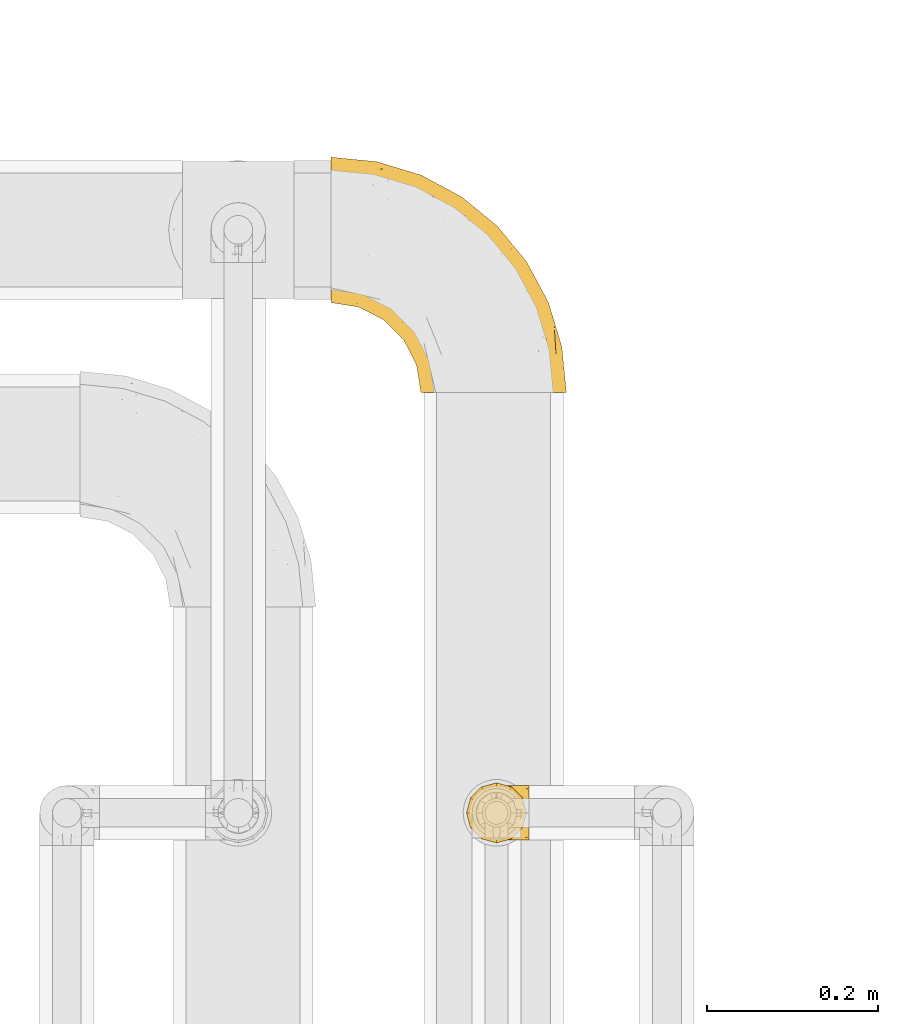
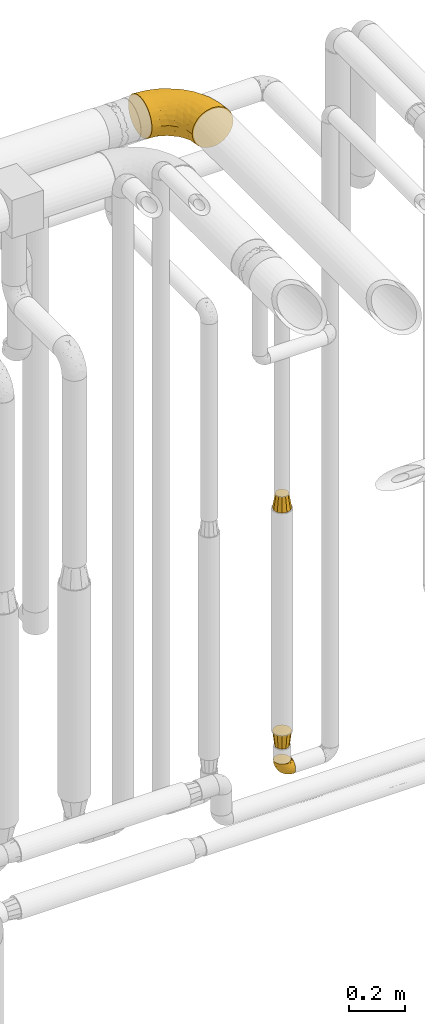
# One storey, part 503 of 827: 4 coverings.
"""IFC2X3 building model written with IfcOpenShell, lengths in millimetres."""

from ifc_helpers import new_model, entity, si_unit, converted_unit, derived_unit, direction, frame, origin, place, context, subcontext, project, spatial, faceted_brep, element, save


model = new_model("IFC2X3")

# Units and contexts
model_context = context("Model", 3, precision=0.01, world=origin(), true_north=direction((6.12303176911189e-17, 1.0)))
body_context = subcontext(model_context, "Body", "Model", "MODEL_VIEW")
ifc_project = project(units=[si_unit("LENGTHUNIT", "METRE", prefix="MILLI"), si_unit("AREAUNIT", "SQUARE_METRE"), si_unit("VOLUMEUNIT", "CUBIC_METRE"), converted_unit("PLANEANGLEUNIT", "DEGREE", entity("IfcRatioMeasure", 0.0174532925199433), si_unit("PLANEANGLEUNIT", "RADIAN"), dimensions=[0, 0, 0, 0, 0, 0, 0]), si_unit("MASSUNIT", "GRAM", prefix="KILO"), derived_unit("MASSDENSITYUNIT", [(si_unit("MASSUNIT", "GRAM", prefix="KILO"), 1), (si_unit("LENGTHUNIT", "METRE"), -3)]), derived_unit("MOMENTOFINERTIAUNIT", [(si_unit("LENGTHUNIT", "METRE"), 4)]), si_unit("TIMEUNIT", "SECOND"), si_unit("FREQUENCYUNIT", "HERTZ"), si_unit("THERMODYNAMICTEMPERATUREUNIT", "DEGREE_CELSIUS"), derived_unit("THERMALTRANSMITTANCEUNIT", [(si_unit("MASSUNIT", "GRAM", prefix="KILO"), 1), (si_unit("THERMODYNAMICTEMPERATUREUNIT", "KELVIN"), -1), (si_unit("TIMEUNIT", "SECOND"), -3)]), derived_unit("VOLUMETRICFLOWRATEUNIT", [(si_unit("LENGTHUNIT", "METRE"), 3), (si_unit("TIMEUNIT", "SECOND"), -1)]), derived_unit("MASSFLOWRATEUNIT", [(si_unit("MASSUNIT", "GRAM", prefix="KILO"), 1), (si_unit("TIMEUNIT", "SECOND"), -1)]), derived_unit("ROTATIONALFREQUENCYUNIT", [(si_unit("TIMEUNIT", "SECOND"), -1)]), si_unit("ELECTRICCURRENTUNIT", "AMPERE"), si_unit("ELECTRICVOLTAGEUNIT", "VOLT"), si_unit("POWERUNIT", "WATT"), si_unit("FORCEUNIT", "NEWTON", prefix="KILO"), si_unit("ILLUMINANCEUNIT", "LUX"), si_unit("LUMINOUSFLUXUNIT", "LUMEN"), si_unit("LUMINOUSINTENSITYUNIT", "CANDELA"), derived_unit("USERDEFINED", [(si_unit("MASSUNIT", "GRAM", prefix="KILO"), -1), (si_unit("LENGTHUNIT", "METRE"), -2), (si_unit("TIMEUNIT", "SECOND"), 3), (si_unit("LUMINOUSFLUXUNIT", "LUMEN"), 1)]), derived_unit("LINEARVELOCITYUNIT", [(si_unit("LENGTHUNIT", "METRE"), 1), (si_unit("TIMEUNIT", "SECOND"), -1)]), si_unit("PRESSUREUNIT", "PASCAL"), derived_unit("USERDEFINED", [(si_unit("LENGTHUNIT", "METRE"), -2), (si_unit("MASSUNIT", "GRAM", prefix="KILO"), 1), (si_unit("TIMEUNIT", "SECOND"), -2)]), derived_unit("LINEARFORCEUNIT", [(si_unit("MASSUNIT", "GRAM", prefix="KILO"), 1), (si_unit("LENGTHUNIT", "METRE"), 1), (si_unit("TIMEUNIT", "SECOND"), -2), (si_unit("LENGTHUNIT", "METRE"), -1)]), derived_unit("PLANARFORCEUNIT", [(si_unit("MASSUNIT", "GRAM", prefix="KILO"), 1), (si_unit("LENGTHUNIT", "METRE"), 1), (si_unit("TIMEUNIT", "SECOND"), -2), (si_unit("LENGTHUNIT", "METRE"), -2)])], contexts=[model_context])

# Site, building, storey
site_placement = place(None, origin())
site = spatial("IfcSite", under=ifc_project, at=site_placement, CompositionType="ELEMENT")
building_placement = place(site_placement, origin())
building = spatial("IfcBuilding", under=site, at=building_placement, CompositionType="ELEMENT")
storey_placement = place(building_placement, frame((0.0, 0.0, 28200.0)))
storey = spatial("IfcBuildingStorey", under=building, at=storey_placement, Name="08", CompositionType="ELEMENT", Elevation=28200.0)

# Coverings
covering_1_placement = place(storey_placement, frame((60420.94, 17466.55, 366.55)))
element("IfcCovering", 1, at=covering_1_placement, inside=storey, Name=":ADSK_", ObjectType=":ADSK_", PredefinedType="INSULATION", context=body_context, shape_type="Brep", body=[
    faceted_brep([(2.39, 40.53, 71.45), (1.6, 33.45, 71.45), (2.39, 26.35, 71.45), (4.75, 19.62, 71.45), (8.55, 13.58, 71.45), (13.59, 8.54, 71.45), (19.63, 4.75, 71.45), (26.36, 2.39, 71.45), (33.45, 1.6, 71.45), (37.35, 2.04, 71.45), (40.54, 2.39, 71.45), (43.9, 3.57, 71.45), (47.27, 4.75, 71.45), (53.31, 8.55, 71.45), (58.35, 13.59, 71.45), (62.14, 19.63, 71.45), (64.5, 26.36, 71.45), (65.3, 33.45, 71.45), (64.5, 40.54, 71.45), (62.14, 47.27, 71.45), (58.34, 53.31, 71.45), (53.3, 58.35, 71.45), (47.26, 62.14, 71.45), (43.89, 63.32, 71.45), (40.53, 64.5, 71.45), (37.35, 64.86, 71.45), (35.4, 65.08, 71.45), (33.45, 65.3, 71.45), (26.35, 64.5, 71.45), (19.62, 62.14, 71.45), (13.58, 58.34, 71.45), (8.54, 53.3, 71.45), (4.75, 47.26, 71.45), (71.45, 5.86, 49.37), (71.45, 4.27, 45.53), (71.45, 2.68, 41.69), (71.45, 2.11, 37.37), (71.45, 1.85, 35.41), (71.45, 1.6, 33.45), (71.45, 2.68, 25.2), (71.45, 5.86, 17.52), (71.45, 10.92, 10.92), (71.45, 17.52, 5.86), (71.45, 25.2, 2.68), (71.45, 33.45, 1.6), (71.45, 41.69, 2.68), (71.45, 49.37, 5.86), (71.45, 55.97, 10.92), (71.45, 61.03, 17.52), (71.45, 64.21, 25.2), (71.45, 65.3, 33.45), (71.45, 64.78, 37.37), (71.45, 64.21, 41.69), (71.45, 62.62, 45.53), (71.45, 61.03, 49.37), (71.45, 58.5, 52.67), (71.45, 55.97, 55.97), (71.45, 49.37, 61.03), (71.45, 41.69, 64.21), (71.45, 33.45, 65.3), (71.45, 25.2, 64.21), (71.45, 17.52, 61.03), (71.45, 10.92, 55.97), (71.45, 8.39, 52.67), (37.48, 64.03, 39.1), (38.54, 65.3, 52.45), (42.01, 65.3, 48.97), (45.49, 65.3, 45.49), (48.97, 65.3, 42.01), (52.45, 65.3, 38.54), (58.08, 33.45, 4.25), (40.84, 56.13, 19.42), (47.91, 61.0, 22.87), (55.67, 57.25, 14.43), (55.18, 44.44, 5.53), (45.13, 50.33, 12.01), (59.19, 51.72, 8.54), (11.67, 54.4, 55.06), (38.17, 41.87, 11.33), (28.82, 48.25, 20.79), (29.48, 64.6, 56.32), (32.11, 60.78, 33.95), (24.68, 61.71, 47.18), (55.82, 64.46, 28.97), (28.37, 55.78, 28.68), (9.18, 40.71, 41.69), (4.95, 42.87, 55.32), (11.17, 47.87, 43.59), (60.89, 62.12, 20.67), (55.35, 65.3, 37.76), (58.25, 65.3, 36.98), (61.15, 65.3, 36.2), (64.05, 65.3, 35.43), (65.9, 65.3, 34.93), (67.75, 65.3, 34.44), (16.27, 59.32, 58.97), (6.97, 49.35, 59.39), (4.25, 33.45, 58.08), (21.84, 62.53, 59.72), (33.94, 65.3, 69.6), (34.44, 65.3, 67.75), (35.43, 65.3, 64.05), (36.2, 65.3, 61.15), (36.98, 65.3, 58.25), (37.76, 65.3, 55.35), (18.84, 57.03, 43.85), (14.39, 52.84, 44.13), (51.68, 38.52, 4.87), (6.91, 33.45, 44.71), (26.05, 41.09, 19.59), (33.38, 33.45, 14.48), (22.05, 33.45, 22.05), (17.7, 44.35, 29.9), (19.21, 51.29, 33.81), (44.71, 33.45, 6.91), (17.7, 38.44, 27.44), (14.48, 33.45, 33.38), (66.98, 57.42, 55.01), (65.01, 61.06, 50.28), (61.98, 61.24, 51.09), (64.85, 64.58, 40.86), (62.15, 64.0, 43.96), (48.67, 64.21, 52.27), (63.81, 44.85, 68.29), (50.71, 61.42, 62.01), (48.45, 61.84, 66.26), (52.85, 59.03, 67.36), (67.6, 41.64, 65.34), (65.48, 38.8, 68.62), (67.1, 33.45, 67.1), (66.68, 54.12, 58.52), (43.2, 64.27, 61.41), (44.92, 63.33, 66.44), (58.1, 54.97, 65.71), (61.92, 54.91, 60.56), (63.17, 49.44, 65.05), (66.68, 49.79, 61.9), (56.7, 59.23, 58.97), (50.86, 62.42, 57.67), (54.42, 59.27, 62.23), (40.7, 64.6, 65.15), (57.76, 63.73, 46.86), (61.34, 50.25, 67.24), (59.9, 54.66, 63.1), (58.0, 62.35, 50.81), (62.43, 59.05, 54.65), (45.83, 64.34, 55.33), (58.99, 59.52, 56.17), (45.9, 63.71, 59.8), (67.3, 61.92, 48.09), (53.12, 64.52, 46.45), (49.43, 64.9, 46.88), (53.9, 63.33, 50.93), (52.92, 62.23, 55.61), (63.81, 22.04, 68.29), (61.35, 16.65, 67.24), (63.17, 17.46, 65.05), (56.72, 7.66, 58.97), (59.87, 12.13, 62.98), (54.39, 7.35, 61.5), (67.59, 25.25, 65.34), (40.71, 2.29, 65.15), (35.43, 1.6, 64.05), (36.2, 1.6, 61.15), (36.98, 1.6, 58.25), (65.48, 28.1, 68.62), (58.19, 4.51, 50.62), (55.78, 2.45, 45.09), (62.46, 5.62, 50.82), (69.6, 1.6, 33.94), (61.15, 1.6, 36.2), (64.05, 1.6, 35.43), (67.75, 1.6, 34.44), (67.39, 6.96, 51.55), (66.16, 4.16, 46.52), (58.11, 6.38, 54.95), (62.44, 7.84, 54.65), (61.95, 10.87, 59.16), (66.68, 17.1, 61.9), (64.85, 2.31, 40.86), (52.45, 1.6, 38.54), (48.97, 1.6, 42.01), (43.18, 2.62, 61.39), (52.88, 7.88, 67.37), (48.46, 5.05, 66.23), (34.44, 1.6, 67.75), (34.93, 1.6, 65.9), (58.11, 11.92, 65.7), (58.25, 1.6, 36.98), (60.72, 2.23, 41.66), (49.13, 2.95, 53.21), (45.49, 1.6, 45.49), (53.71, 3.29, 50.1), (44.93, 3.56, 66.44), (67.04, 9.57, 55.11), (66.6, 12.74, 58.52), (44.91, 2.39, 55.59), (50.72, 5.47, 62.01), (37.76, 1.6, 55.35), (38.54, 1.6, 52.45), (46.39, 3.46, 60.71), (57.7, 2.2, 42.77), (55.35, 1.6, 37.76), (62.73, 4.02, 47.15), (42.01, 1.6, 48.97), (55.67, 9.64, 14.42), (21.85, 4.35, 59.72), (29.49, 2.29, 56.32), (55.82, 2.43, 28.97), (38.17, 25.02, 11.33), (55.18, 22.45, 5.53), (45.12, 16.56, 12.01), (47.92, 5.89, 22.86), (37.47, 2.86, 39.12), (32.11, 6.1, 33.96), (40.85, 10.76, 19.42), (51.68, 28.37, 4.87), (60.89, 4.77, 20.67), (59.19, 15.17, 8.55), (24.69, 5.18, 47.18), (16.28, 7.56, 58.97), (18.85, 9.85, 43.86), (11.19, 19.01, 43.58), (4.95, 24.01, 55.32), (9.19, 26.18, 41.67), (11.68, 12.48, 55.05), (26.05, 25.8, 19.59), (19.23, 15.6, 33.79), (14.4, 14.04, 44.12), (6.97, 17.53, 59.39), (28.8, 18.64, 20.81), (17.7, 22.54, 29.91), (28.37, 11.1, 28.68), (17.7, 28.45, 27.45)], [[[0, 1, 2, 3, 4, 5, 6, 7, 8, 9, 10, 11, 12, 13, 14, 15, 16, 17, 18, 19, 20, 21, 22, 23, 24, 25, 26, 27, 28, 29, 30, 31, 32]], [[33, 34, 35, 36, 37, 38, 39, 40, 41, 42, 43, 44, 45, 46, 47, 48, 49, 50, 51, 52, 53, 54, 55, 56, 57, 58, 59, 60, 61, 62, 63]], [[64, 65, 66, 67, 68, 69]], [[45, 44, 70]], [[71, 72, 73]], [[74, 75, 76]], [[77, 31, 30]], [[75, 78, 79]], [[27, 80, 28]], [[74, 46, 45]], [[64, 81, 82]], [[46, 76, 47]], [[83, 50, 49]], [[48, 47, 73]], [[71, 79, 84]], [[85, 86, 87]], [[49, 48, 88]], [[83, 69, 89, 90, 91, 92, 93, 94, 50]], [[95, 77, 30]], [[75, 74, 78]], [[87, 86, 96]], [[96, 86, 32]], [[96, 32, 31]], [[0, 86, 97]], [[83, 64, 69]], [[98, 80, 82]], [[73, 72, 88]], [[64, 80, 65]], [[1, 0, 97]], [[80, 27, 99, 100, 101, 102, 103, 104, 65]], [[77, 105, 106]], [[64, 82, 80]], [[70, 107, 45]], [[77, 95, 105]], [[82, 95, 98]], [[95, 30, 29]], [[74, 107, 78]], [[86, 0, 32]], [[72, 71, 81]], [[85, 108, 86]], [[76, 73, 47]], [[71, 84, 81]], [[109, 110, 111]], [[87, 112, 85]], [[79, 109, 112]], [[79, 112, 113]], [[88, 83, 49]], [[64, 83, 72]], [[31, 77, 96]], [[87, 96, 77]], [[98, 95, 29]], [[105, 95, 82]], [[81, 105, 82]], [[105, 84, 113]], [[29, 28, 98]], [[114, 107, 70]], [[80, 98, 28]], [[73, 75, 71]], [[79, 71, 75]], [[74, 76, 46]], [[73, 76, 75]], [[78, 107, 114]], [[45, 107, 74]], [[87, 113, 112]], [[115, 85, 112]], [[109, 79, 78]], [[113, 87, 106]], [[116, 115, 111]], [[116, 108, 85]], [[79, 113, 84]], [[109, 78, 110]], [[115, 109, 111]], [[85, 115, 116]], [[109, 115, 112]], [[72, 81, 64]], [[105, 81, 84]], [[73, 88, 48]], [[83, 88, 72]], [[86, 108, 97]], [[78, 114, 110]], [[113, 106, 105]], [[87, 77, 106]], [[117, 118, 119]], [[52, 120, 54, 53]], [[91, 120, 52]], [[91, 90, 120]], [[90, 121, 120]], [[122, 67, 66]], [[18, 123, 19]], [[124, 125, 126]], [[127, 59, 58]], [[128, 129, 127]], [[130, 57, 117]], [[131, 132, 125]], [[19, 133, 20]], [[128, 18, 17]], [[134, 135, 136]], [[137, 138, 139]], [[131, 103, 140]], [[22, 140, 23]], [[131, 65, 104, 103]], [[99, 27, 26, 25, 24, 101, 100]], [[141, 118, 121]], [[19, 123, 142]], [[52, 51, 50, 94, 93, 92, 91]], [[129, 128, 17]], [[117, 56, 118]], [[135, 134, 143]], [[139, 126, 133]], [[119, 144, 145]], [[127, 135, 123]], [[136, 58, 57]], [[101, 24, 23]], [[124, 138, 146]], [[140, 101, 23]], [[145, 147, 134]], [[140, 132, 131]], [[140, 103, 102, 101]], [[140, 22, 132]], [[146, 148, 124]], [[121, 69, 141]], [[55, 149, 118]], [[150, 151, 152]], [[147, 137, 134]], [[144, 150, 152]], [[152, 151, 122]], [[138, 122, 146]], [[59, 127, 129]], [[123, 18, 128]], [[58, 136, 127]], [[135, 127, 136]], [[121, 90, 89, 69]], [[120, 121, 149]], [[122, 66, 146]], [[153, 122, 138]], [[141, 69, 68]], [[127, 123, 128]], [[123, 135, 142]], [[143, 142, 135]], [[19, 142, 133]], [[66, 65, 146]], [[148, 65, 131]], [[22, 21, 132]], [[125, 132, 21]], [[126, 125, 21]], [[148, 125, 124]], [[21, 20, 126]], [[133, 126, 20]], [[139, 138, 124]], [[153, 138, 137]], [[126, 139, 124]], [[139, 133, 143]], [[147, 153, 137]], [[152, 122, 153]], [[134, 136, 130]], [[137, 139, 143]], [[144, 147, 145]], [[153, 147, 152]], [[65, 148, 146]], [[125, 148, 131]], [[141, 144, 119]], [[55, 54, 149]], [[137, 143, 134]], [[142, 143, 133]], [[130, 117, 145]], [[57, 56, 117]], [[134, 130, 145]], [[57, 130, 136]], [[150, 144, 141]], [[147, 144, 152]], [[141, 68, 150]], [[151, 68, 67]], [[117, 119, 145]], [[141, 119, 118]], [[68, 151, 150]], [[122, 151, 67]], [[118, 56, 55]], [[120, 149, 54]], [[118, 149, 121]], [[154, 155, 156]], [[157, 158, 159]], [[129, 160, 59]], [[161, 162, 163, 164]], [[165, 160, 129]], [[166, 167, 168]], [[169, 38, 37, 36, 35, 170, 171, 172]], [[63, 173, 174]], [[175, 176, 177]], [[60, 178, 61]], [[179, 35, 34, 33]], [[160, 60, 59]], [[180, 167, 181]], [[129, 17, 165]], [[182, 161, 164]], [[183, 13, 184]], [[9, 8, 185, 186, 162, 10]], [[187, 155, 15]], [[188, 179, 189]], [[187, 15, 14]], [[190, 191, 192]], [[182, 193, 161]], [[194, 176, 168]], [[176, 195, 177]], [[196, 190, 197]], [[11, 10, 162]], [[11, 161, 12]], [[187, 14, 183]], [[12, 161, 193]], [[156, 158, 177]], [[165, 17, 16]], [[194, 195, 176]], [[187, 159, 158]], [[179, 174, 189]], [[182, 164, 198, 199]], [[200, 199, 196]], [[193, 184, 13]], [[194, 168, 173]], [[201, 202, 189]], [[16, 154, 165]], [[160, 156, 178]], [[160, 165, 154]], [[178, 60, 160]], [[170, 35, 179]], [[188, 170, 179]], [[189, 174, 203]], [[174, 179, 33]], [[201, 189, 203]], [[181, 192, 191]], [[167, 180, 201]], [[192, 175, 190]], [[159, 190, 157]], [[15, 154, 16]], [[204, 196, 199]], [[204, 191, 190]], [[160, 154, 156]], [[15, 155, 154]], [[158, 155, 187]], [[203, 173, 168]], [[192, 181, 167]], [[190, 196, 204]], [[200, 196, 197]], [[184, 193, 182]], [[13, 12, 193]], [[200, 184, 182]], [[184, 200, 183]], [[187, 183, 197]], [[14, 13, 183]], [[162, 161, 11]], [[63, 62, 173]], [[174, 33, 63]], [[173, 62, 194]], [[174, 173, 203]], [[62, 61, 194]], [[195, 61, 178]], [[61, 195, 194]], [[177, 195, 178]], [[156, 177, 178]], [[175, 192, 166]], [[166, 168, 176]], [[167, 203, 168]], [[175, 166, 176]], [[167, 166, 192]], [[177, 157, 175]], [[190, 175, 157]], [[187, 197, 159]], [[190, 159, 197]], [[177, 158, 157]], [[155, 158, 156]], [[167, 201, 203]], [[200, 197, 183]], [[202, 201, 180]], [[202, 188, 189]], [[199, 200, 182]], [[41, 40, 205]], [[206, 207, 7]], [[208, 38, 169, 172, 171, 170, 188, 202, 180]], [[209, 210, 211]], [[212, 213, 214]], [[212, 215, 205]], [[43, 210, 216]], [[217, 40, 39]], [[216, 114, 70]], [[208, 213, 212]], [[205, 40, 217]], [[218, 42, 41]], [[216, 209, 114]], [[42, 218, 210]], [[214, 213, 219]], [[219, 220, 221]], [[199, 207, 213]], [[213, 207, 219]], [[8, 7, 207]], [[222, 223, 224]], [[4, 225, 5]], [[2, 97, 223]], [[110, 226, 111]], [[225, 220, 5]], [[227, 221, 228]], [[223, 229, 3]], [[2, 223, 3]], [[230, 231, 226]], [[224, 223, 108]], [[42, 210, 43]], [[230, 209, 211]], [[222, 225, 229]], [[38, 208, 39]], [[3, 229, 4]], [[213, 180, 181, 191, 204, 199]], [[220, 206, 6]], [[5, 220, 6]], [[207, 199, 198, 164, 163, 162, 186, 185, 8]], [[212, 214, 215]], [[218, 205, 211]], [[211, 215, 230]], [[226, 110, 209]], [[222, 231, 227]], [[222, 224, 231]], [[213, 208, 180]], [[217, 208, 212]], [[222, 229, 223]], [[225, 4, 229]], [[221, 220, 225]], [[206, 220, 219]], [[228, 221, 225]], [[214, 221, 232]], [[207, 206, 219]], [[44, 43, 70]], [[7, 6, 206]], [[230, 215, 232]], [[211, 205, 215]], [[205, 218, 41]], [[210, 218, 211]], [[43, 216, 70]], [[209, 216, 210]], [[233, 116, 111]], [[230, 232, 227]], [[224, 116, 233]], [[230, 226, 209]], [[224, 108, 116]], [[230, 227, 231]], [[221, 227, 232]], [[233, 226, 231]], [[225, 222, 228]], [[226, 233, 111]], [[224, 233, 231]], [[221, 214, 219]], [[214, 232, 215]], [[208, 217, 39]], [[205, 217, 212]], [[97, 2, 1]], [[97, 108, 223]], [[110, 114, 209]], [[227, 228, 222]]]),
])
covering_2_placement = place(storey_placement, frame((60417.79, 17463.4, 500.0)))
element("IfcCovering", 2, at=covering_2_placement, inside=storey, Name=":ADSK_", ObjectType=":ADSK_", PredefinedType="INSULATION", context=body_context, shape_type="Brep", body=[
    faceted_brep([(12.69, 60.5, 64.0), (6.28, 54.1, 64.0), (3.96, 45.43, 64.0), (1.6, 36.6, 64.0), (3.96, 27.76, 64.0), (6.28, 19.1, 64.0), (12.69, 12.69, 64.0), (19.1, 6.28, 64.0), (27.76, 3.96, 64.0), (36.6, 1.6, 64.0), (45.43, 3.96, 64.0), (54.1, 6.28, 64.0), (60.5, 12.69, 64.0), (66.91, 19.1, 64.0), (69.23, 27.76, 64.0), (71.6, 36.6, 64.0), (69.23, 45.43, 64.0), (66.91, 54.1, 64.0), (60.5, 60.5, 64.0), (54.1, 66.91, 64.0), (45.43, 69.23, 64.0), (36.6, 71.6, 64.0), (27.76, 69.23, 64.0), (19.1, 66.91, 64.0), (50.35, 60.41, 0.0), (55.38, 55.38, 0.0), (60.41, 50.35, 0.0), (62.25, 43.47, 0.0), (64.1, 36.6, 0.0), (62.25, 29.72, 0.0), (60.41, 22.85, 0.0), (55.38, 17.81, 0.0), (50.35, 12.78, 0.0), (43.47, 10.94, 0.0), (36.6, 9.1, 0.0), (29.72, 10.94, 0.0), (22.85, 12.78, 0.0), (17.81, 17.81, 0.0), (12.78, 22.85, 0.0), (10.94, 29.72, 0.0), (9.1, 36.6, 0.0), (10.94, 43.47, 0.0), (12.78, 50.35, 0.0), (17.81, 55.38, 0.0), (22.85, 60.41, 0.0), (29.72, 62.25, 0.0), (36.6, 64.1, 0.0), (43.47, 62.25, 0.0)], [[[0, 1, 2, 3, 4, 5, 6, 7, 8, 9, 10, 11, 12, 13, 14, 15, 16, 17, 18, 19, 20, 21, 22, 23]], [[24, 25, 26, 27, 28, 29, 30, 31, 32, 33, 34, 35, 36, 37, 38, 39, 40, 41, 42, 43, 44, 45, 46, 47]], [[38, 5, 4, 3, 40, 39]], [[6, 5, 38, 37, 36, 7]], [[35, 34, 9, 8, 7, 36]], [[32, 11, 10, 9, 34, 33]], [[12, 11, 32, 31, 30, 13]], [[29, 28, 15, 14, 13, 30]], [[26, 17, 16, 15, 28, 27]], [[18, 17, 26, 25, 24, 19]], [[47, 46, 21, 20, 19, 24]], [[44, 23, 22, 21, 46, 45]], [[0, 23, 44, 43, 42, 1]], [[41, 40, 3, 2, 1, 42]]]),
])
covering_3_placement = place(storey_placement, frame((60417.79, 17463.4, 1536.0)))
element("IfcCovering", 3, at=covering_3_placement, inside=storey, Name=":ADSK_", ObjectType=":ADSK_", PredefinedType="INSULATION", context=body_context, shape_type="Brep", body=[
    faceted_brep([(49.1, 58.25, 64.0), (42.85, 59.92, 64.0), (36.6, 61.6, 64.0), (30.35, 59.92, 64.0), (24.1, 58.25, 64.0), (19.52, 53.67, 64.0), (14.94, 49.1, 64.0), (13.27, 42.85, 64.0), (11.6, 36.6, 64.0), (13.27, 30.35, 64.0), (14.94, 24.1, 64.0), (19.52, 19.52, 64.0), (24.1, 14.94, 64.0), (30.35, 13.27, 64.0), (36.6, 11.6, 64.0), (42.85, 13.27, 64.0), (49.1, 14.94, 64.0), (53.67, 19.52, 64.0), (58.25, 24.1, 64.0), (59.92, 30.35, 64.0), (61.6, 36.6, 64.0), (59.92, 42.85, 64.0), (58.25, 49.1, 64.0), (53.67, 53.67, 64.0), (60.5, 60.5, 0.0), (66.91, 54.1, 0.0), (69.29, 45.21, 0.0), (71.6, 36.6, 0.0), (69.29, 27.98, 0.0), (66.91, 19.1, 0.0), (60.5, 12.69, 0.0), (54.1, 6.28, 0.0), (45.21, 3.9, 0.0), (36.6, 1.6, 0.0), (27.98, 3.9, 0.0), (19.1, 6.28, 0.0), (12.69, 12.69, 0.0), (6.28, 19.1, 0.0), (3.9, 27.98, 0.0), (1.6, 36.6, 0.0), (3.9, 45.21, 0.0), (6.28, 54.1, 0.0), (12.69, 60.5, 0.0), (19.1, 66.91, 0.0), (27.98, 69.29, 0.0), (36.6, 71.6, 0.0), (45.21, 69.29, 0.0), (54.1, 66.91, 0.0)], [[[0, 1, 2, 3, 4, 5, 6, 7, 8, 9, 10, 11, 12, 13, 14, 15, 16, 17, 18, 19, 20, 21, 22, 23]], [[24, 25, 26, 27, 28, 29, 30, 31, 32, 33, 34, 35, 36, 37, 38, 39, 40, 41, 42, 43, 44, 45, 46, 47]], [[35, 34, 33, 14, 13, 12]], [[11, 10, 37, 36, 35, 12]], [[38, 37, 10, 9, 8, 39]], [[29, 28, 27, 20, 19, 18]], [[17, 16, 31, 30, 29, 18]], [[32, 31, 16, 15, 14, 33]], [[47, 46, 45, 2, 1, 0]], [[23, 22, 25, 24, 47, 0]], [[26, 25, 22, 21, 20, 27]], [[41, 40, 39, 8, 7, 6]], [[5, 4, 43, 42, 41, 6]], [[44, 43, 4, 3, 2, 45]]]),
])
covering_4_placement = place(storey_placement, frame((60259.45, 17988.5, 2813.55)))
element("IfcCovering", 4, at=covering_4_placement, inside=storey, Name=":ADSK_", ObjectType=":ADSK_", PredefinedType="INSULATION", context=body_context, shape_type="Brep", body=[
    faceted_brep([(1.6, 220.62, 166.18), (1.6, 234.03, 159.92), (1.6, 246.14, 151.44), (1.6, 256.6, 140.98), (1.6, 265.08, 128.87), (1.6, 271.33, 115.47), (1.6, 275.16, 101.18), (1.6, 276.45, 86.45), (1.6, 275.16, 71.71), (1.6, 271.33, 57.42), (1.6, 265.07, 44.02), (1.6, 256.59, 31.9), (1.6, 246.13, 21.44), (1.6, 234.02, 12.96), (1.6, 220.62, 6.71), (1.6, 206.33, 2.88), (1.6, 191.6, 1.6), (1.6, 176.86, 2.89), (1.6, 162.57, 6.71), (1.6, 149.17, 12.97), (1.6, 137.05, 21.45), (1.6, 126.59, 31.91), (1.6, 118.11, 44.02), (1.6, 111.86, 57.42), (1.6, 108.03, 71.71), (1.6, 106.75, 86.45), (1.6, 108.04, 101.18), (1.6, 111.86, 115.47), (1.6, 118.12, 128.88), (1.6, 126.6, 140.99), (1.6, 137.06, 151.45), (1.6, 149.17, 159.93), (1.6, 162.57, 166.18), (1.6, 176.86, 170.01), (1.6, 191.6, 171.3), (1.6, 206.33, 170.01), (131.6, 1.6, 26.45), (149.17, 1.6, 12.96), (169.63, 1.6, 4.49), (191.6, 1.6, 1.6), (213.56, 1.6, 4.49), (234.02, 1.6, 12.96), (251.59, 1.6, 26.45), (265.08, 1.6, 44.02), (273.55, 1.6, 64.48), (276.45, 1.6, 86.45), (273.55, 1.6, 108.41), (265.08, 1.6, 128.87), (251.59, 1.6, 146.44), (234.02, 1.6, 159.93), (213.56, 1.6, 168.4), (191.6, 1.6, 171.3), (169.63, 1.6, 168.4), (149.17, 1.6, 159.93), (131.6, 1.6, 146.44), (118.11, 1.6, 128.87), (109.64, 1.6, 108.41), (106.75, 1.6, 86.45), (109.64, 1.6, 64.48), (118.11, 1.6, 44.02), (262.36, 78.36, 108.89), (271.16, 55.22, 86.45), (255.52, 106.78, 86.45), (50.98, 227.56, 160.57), (172.61, 210.93, 113.84), (203.97, 166.54, 132.78), (212.76, 169.48, 115.35), (195.94, 195.94, 86.45), (169.94, 121.35, 169.66), (120.06, 150.14, 171.3), (135.1, 135.1, 171.3), (150.14, 120.06, 171.3), (237.65, 124.32, 124.06), (241.63, 130.67, 106.11), (58.66, 210.57, 167.01), (229.96, 93.72, 149.97), (211.71, 139.64, 145.0), (192.74, 144.17, 156.09), (230.12, 154.29, 86.45), (158.59, 208.4, 134.92), (110.39, 240.3, 130.81), (119.11, 221.79, 146.85), (154.29, 230.12, 86.45), (62.72, 262.33, 120.3), (111.17, 248.26, 114.99), (79.56, 263.49, 102.82), (253.1, 63.94, 135.66), (235.85, 108.29, 137.97), (195.66, 79.35, 169.13), (241.79, 42.69, 152.15), (55.22, 271.16, 86.45), (106.78, 255.52, 86.45), (217.39, 76.62, 162.08), (99.75, 212.49, 159.81), (264.19, 49.07, 122.41), (186.11, 126.68, 164.65), (153.25, 177.19, 160.16), (177.64, 177.64, 147.45), (119.88, 179.24, 168.0), (172.78, 84.03, 171.3), (84.03, 172.78, 171.3), (62.89, 246.43, 143.95), (186.83, 43.87, 171.3), (43.87, 186.83, 171.3), (113.05, 35.25, 128.7), (100.5, 55.06, 120.84), (106.86, 29.97, 111.79), (163.63, 40.1, 167.99), (25.67, 174.11, 169.81), (62.91, 141.82, 162.83), (91.14, 151.41, 169.87), (66.45, 162.23, 169.62), (106.25, 68.19, 139.83), (117.34, 78.22, 154.11), (94.43, 94.43, 147.7), (85.43, 83.32, 129.83), (32.15, 106.07, 111.24), (57.82, 95.5, 113.13), (52.87, 105.97, 128.47), (135.69, 106.13, 168.91), (127.24, 90.7, 163.29), (150.81, 84.2, 169.04), (86.66, 63.4, 86.45), (96.24, 50.79, 102.42), (78.07, 78.07, 108.81), (142.05, 30.53, 157.36), (122.04, 42.81, 143.61), (71.57, 119.66, 152.9), (88.75, 127.3, 162.78), (34.09, 101.6, 86.45), (63.4, 86.66, 86.45), (117.23, 132.44, 169.89), (43.38, 118.77, 140.27), (26.96, 113.91, 126.4), (101.6, 34.09, 86.45), (114.56, 114.56, 165.72), (38.85, 159.75, 166.71), (67.12, 108.44, 141.38), (28.1, 145.49, 159.19), (106.51, 101.13, 158.14), (36.78, 131.96, 151.08), (137.5, 64.62, 161.17), (78.07, 78.07, 64.08), (186.83, 43.87, 1.6), (163.63, 40.1, 4.9), (172.78, 84.03, 1.6), (106.86, 29.97, 61.1), (96.24, 50.79, 70.47), (25.67, 174.1, 3.08), (100.5, 55.06, 52.05), (113.05, 35.25, 44.19), (57.82, 95.5, 59.77), (85.44, 83.31, 43.07), (106.25, 68.19, 33.07), (52.86, 105.97, 44.43), (67.12, 108.44, 31.51), (142.05, 30.53, 15.53), (122.04, 42.81, 29.28), (137.5, 64.63, 11.72), (32.15, 106.07, 61.65), (150.8, 84.21, 3.85), (150.14, 120.06, 1.6), (66.45, 162.23, 3.27), (43.87, 186.83, 1.6), (84.03, 172.78, 1.6), (71.57, 119.66, 19.99), (36.79, 131.95, 21.82), (62.92, 141.81, 10.07), (26.95, 113.91, 46.49), (88.75, 127.29, 10.11), (35.6, 145.35, 12.88), (43.38, 118.77, 32.63), (127.23, 90.7, 9.6), (135.68, 106.13, 3.98), (135.1, 135.1, 1.6), (117.33, 78.22, 18.78), (38.86, 159.75, 6.18), (91.14, 151.41, 3.02), (120.06, 150.14, 1.6), (117.23, 132.44, 3.0), (114.56, 114.56, 7.17), (106.5, 101.13, 14.75), (94.43, 94.43, 25.19), (195.66, 79.35, 3.76), (169.94, 121.35, 3.23), (186.11, 126.68, 8.24), (262.36, 78.36, 64.0), (58.66, 210.57, 5.88), (99.75, 212.49, 13.07), (153.26, 177.18, 12.73), (119.88, 179.23, 4.89), (119.11, 221.79, 26.04), (212.77, 169.48, 57.54), (217.39, 76.62, 10.82), (255.51, 82.71, 49.85), (253.1, 63.94, 37.23), (235.86, 108.29, 34.92), (241.79, 42.69, 20.74), (229.96, 93.72, 22.92), (172.61, 210.93, 59.05), (111.17, 248.25, 57.9), (177.64, 177.64, 25.44), (158.58, 208.4, 37.97), (237.65, 124.32, 48.83), (241.63, 130.67, 66.78), (211.71, 139.64, 27.89), (62.72, 262.33, 52.59), (203.97, 166.55, 40.11), (62.88, 246.43, 28.94), (50.99, 227.55, 12.32), (192.75, 144.16, 16.8), (79.56, 263.49, 70.06), (110.39, 240.3, 42.07)], [[[0, 1, 2, 3, 4, 5, 6, 7, 8, 9, 10, 11, 12, 13, 14, 15, 16, 17, 18, 19, 20, 21, 22, 23, 24, 25, 26, 27, 28, 29, 30, 31, 32, 33, 34, 35]], [[36, 37, 38, 39, 40, 41, 42, 43, 44, 45, 46, 47, 48, 49, 50, 51, 52, 53, 54, 55, 56, 57, 58, 59]], [[60, 61, 62]], [[61, 46, 45]], [[63, 2, 1]], [[64, 65, 66]], [[64, 66, 67]], [[68, 69, 70, 71]], [[72, 73, 66]], [[74, 0, 35]], [[75, 76, 77]], [[78, 73, 62]], [[79, 80, 81]], [[64, 67, 82]], [[83, 84, 85]], [[86, 48, 47]], [[65, 76, 87]], [[51, 50, 88]], [[75, 89, 86]], [[90, 85, 91]], [[75, 77, 92]], [[74, 93, 63]], [[94, 46, 60]], [[95, 68, 88]], [[96, 97, 81]], [[96, 93, 98]], [[88, 68, 99]], [[98, 100, 69]], [[83, 101, 80]], [[101, 63, 81]], [[48, 89, 49]], [[79, 65, 64]], [[85, 6, 5]], [[101, 83, 3]], [[50, 92, 88]], [[83, 85, 5]], [[94, 86, 47]], [[3, 83, 4]], [[75, 87, 76]], [[90, 7, 6]], [[88, 99, 102]], [[101, 3, 2]], [[100, 98, 74]], [[100, 74, 103]], [[4, 83, 5]], [[34, 103, 35]], [[51, 88, 102]], [[85, 84, 91]], [[72, 86, 94]], [[81, 80, 101]], [[103, 74, 35]], [[98, 69, 68]], [[98, 93, 74]], [[74, 63, 0]], [[63, 101, 2]], [[50, 49, 92]], [[46, 61, 60]], [[84, 82, 91]], [[89, 92, 49]], [[95, 88, 92]], [[6, 85, 90]], [[83, 80, 84]], [[96, 81, 93]], [[79, 81, 97]], [[65, 79, 97]], [[64, 80, 79]], [[76, 65, 97]], [[65, 72, 66]], [[80, 64, 84]], [[82, 84, 64]], [[73, 72, 60]], [[67, 66, 78]], [[62, 73, 60]], [[78, 66, 73]], [[98, 95, 96]], [[77, 96, 95]], [[98, 68, 95]], [[99, 68, 71]], [[63, 93, 81]], [[0, 63, 1]], [[77, 76, 97]], [[75, 86, 87]], [[96, 77, 97]], [[77, 95, 92]], [[86, 72, 87]], [[65, 87, 72]], [[86, 89, 48]], [[92, 89, 75]], [[46, 94, 47]], [[72, 94, 60]], [[104, 105, 106]], [[52, 51, 102]], [[52, 102, 107]], [[33, 108, 103]], [[109, 110, 111]], [[112, 113, 114]], [[114, 115, 112]], [[99, 107, 102]], [[116, 117, 118]], [[119, 120, 121]], [[122, 123, 124]], [[53, 125, 54]], [[125, 126, 54]], [[127, 128, 109]], [[26, 129, 116]], [[130, 122, 124]], [[128, 131, 110]], [[57, 56, 106]], [[132, 28, 133]], [[106, 105, 123]], [[122, 134, 123]], [[135, 120, 119]], [[28, 132, 29]], [[121, 107, 99]], [[103, 108, 111]], [[107, 53, 52]], [[115, 124, 105]], [[136, 32, 31]], [[117, 129, 130]], [[34, 33, 103]], [[132, 137, 127]], [[136, 31, 138]], [[139, 114, 113]], [[32, 108, 33]], [[127, 114, 139]], [[30, 140, 138]], [[129, 26, 25]], [[133, 116, 118]], [[54, 126, 55]], [[126, 112, 104]], [[27, 26, 116]], [[116, 133, 27]], [[140, 30, 29]], [[117, 130, 124]], [[131, 119, 70]], [[109, 140, 127]], [[109, 136, 138]], [[118, 117, 115]], [[127, 140, 132]], [[110, 131, 69]], [[32, 136, 108]], [[125, 107, 141]], [[111, 108, 136]], [[105, 104, 112]], [[115, 114, 137]], [[107, 125, 53]], [[126, 125, 141]], [[105, 112, 115]], [[113, 126, 141]], [[126, 113, 112]], [[120, 113, 141]], [[134, 57, 106]], [[124, 123, 105]], [[134, 106, 123]], [[104, 56, 55]], [[56, 104, 106]], [[55, 126, 104]], [[120, 141, 121]], [[139, 120, 135]], [[107, 121, 141]], [[71, 121, 99]], [[121, 71, 119]], [[119, 71, 70]], [[131, 70, 69]], [[69, 100, 110]], [[119, 131, 135]], [[111, 110, 100]], [[110, 109, 128]], [[117, 116, 129]], [[115, 117, 124]], [[120, 139, 113]], [[139, 135, 128]], [[132, 133, 118]], [[27, 133, 28]], [[132, 118, 137]], [[29, 132, 140]], [[115, 137, 118]], [[114, 127, 137]], [[103, 111, 100]], [[109, 111, 136]], [[139, 128, 127]], [[128, 135, 131]], [[30, 138, 31]], [[109, 138, 140]], [[122, 130, 142]], [[143, 144, 145]], [[57, 134, 146]], [[146, 134, 147]], [[17, 148, 18]], [[149, 150, 146]], [[142, 149, 147]], [[122, 147, 134]], [[130, 129, 151]], [[150, 58, 146]], [[149, 152, 153]], [[154, 155, 152]], [[37, 144, 38]], [[39, 38, 143]], [[37, 36, 156]], [[156, 157, 158]], [[159, 154, 151]], [[144, 143, 38]], [[145, 160, 161]], [[36, 59, 157]], [[162, 163, 164]], [[165, 166, 167]], [[154, 159, 168]], [[162, 148, 163]], [[129, 25, 24]], [[169, 165, 167]], [[170, 20, 19]], [[168, 23, 22]], [[171, 21, 166]], [[160, 158, 172]], [[161, 173, 174]], [[165, 155, 171]], [[151, 129, 159]], [[20, 166, 21]], [[175, 172, 158]], [[170, 176, 167]], [[177, 178, 179]], [[179, 173, 180]], [[162, 164, 177]], [[152, 149, 142]], [[170, 167, 166]], [[171, 154, 168]], [[17, 16, 163]], [[129, 24, 159]], [[165, 169, 181]], [[17, 163, 148]], [[176, 19, 18]], [[153, 175, 157]], [[160, 144, 158]], [[23, 159, 24]], [[171, 155, 154]], [[156, 144, 37]], [[176, 18, 148]], [[152, 142, 151]], [[153, 152, 182]], [[157, 156, 36]], [[144, 156, 158]], [[175, 153, 182]], [[153, 157, 150]], [[181, 175, 182]], [[157, 175, 158]], [[142, 147, 122]], [[146, 147, 149]], [[153, 150, 149]], [[146, 58, 57]], [[157, 59, 150]], [[58, 150, 59]], [[181, 172, 175]], [[172, 173, 160]], [[172, 180, 173]], [[144, 160, 145]], [[174, 173, 179]], [[161, 160, 173]], [[174, 179, 178]], [[179, 169, 177]], [[178, 177, 164]], [[169, 179, 180]], [[162, 167, 176]], [[152, 151, 154]], [[130, 151, 142]], [[165, 181, 182]], [[172, 181, 180]], [[23, 168, 159]], [[22, 21, 171]], [[171, 168, 22]], [[165, 171, 166]], [[165, 182, 155]], [[152, 155, 182]], [[167, 162, 177]], [[162, 176, 148]], [[177, 169, 167]], [[181, 169, 180]], [[20, 170, 166]], [[19, 176, 170]], [[183, 184, 185]], [[43, 186, 44]], [[61, 44, 186]], [[183, 39, 143]], [[145, 161, 184]], [[62, 61, 186]], [[187, 164, 163]], [[188, 189, 190]], [[188, 191, 189]], [[178, 190, 184]], [[192, 67, 78]], [[193, 183, 185]], [[194, 43, 195]], [[195, 196, 194]], [[61, 45, 44]], [[40, 193, 41]], [[41, 197, 42]], [[197, 193, 198]], [[82, 199, 200]], [[201, 191, 202]], [[42, 197, 195]], [[203, 192, 204]], [[15, 187, 163]], [[62, 186, 204]], [[195, 43, 42]], [[190, 185, 184]], [[190, 178, 164]], [[196, 198, 205]], [[206, 10, 9]], [[205, 201, 207]], [[163, 16, 15]], [[14, 187, 15]], [[12, 208, 209]], [[39, 183, 40]], [[208, 12, 11]], [[205, 210, 201]], [[185, 210, 193]], [[13, 209, 14]], [[188, 190, 187]], [[206, 211, 200]], [[82, 67, 199]], [[208, 11, 206]], [[203, 207, 192]], [[90, 91, 211]], [[191, 188, 209]], [[206, 11, 10]], [[211, 8, 90]], [[9, 8, 211]], [[7, 90, 8]], [[191, 208, 212]], [[191, 209, 208]], [[208, 206, 212]], [[200, 212, 206]], [[145, 183, 143]], [[193, 40, 183]], [[188, 187, 209]], [[187, 190, 164]], [[202, 207, 201]], [[91, 82, 200]], [[211, 206, 9]], [[202, 191, 212]], [[189, 191, 201]], [[212, 199, 202]], [[199, 192, 207]], [[199, 207, 202]], [[195, 198, 196]], [[200, 211, 91]], [[199, 212, 200]], [[67, 192, 199]], [[204, 186, 194]], [[192, 78, 204]], [[62, 204, 78]], [[210, 189, 201]], [[185, 190, 189]], [[145, 184, 183]], [[184, 161, 174, 178]], [[14, 209, 187]], [[209, 13, 12]], [[196, 207, 203]], [[198, 193, 210]], [[198, 210, 205]], [[189, 210, 185]], [[207, 196, 205]], [[194, 196, 203]], [[193, 197, 41]], [[195, 197, 198]], [[204, 194, 203]], [[43, 194, 186]]]),
])

save(model, "model.ifc")
